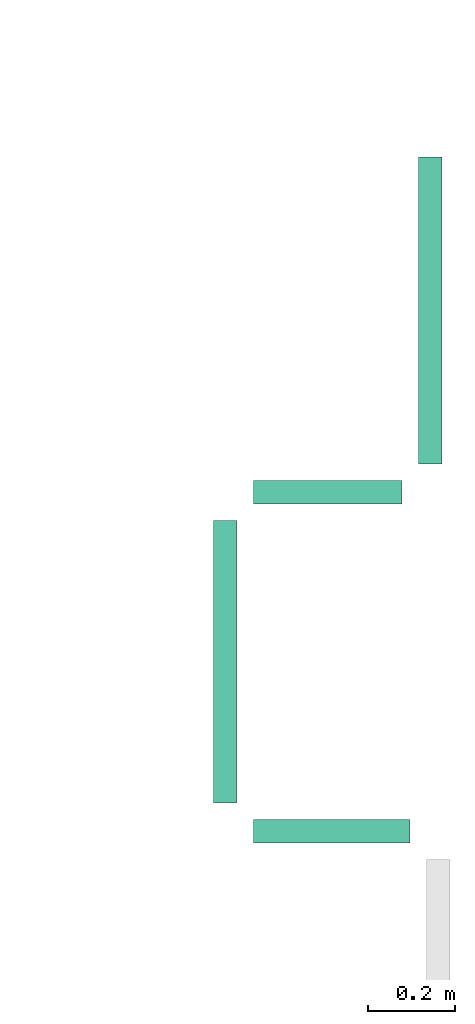
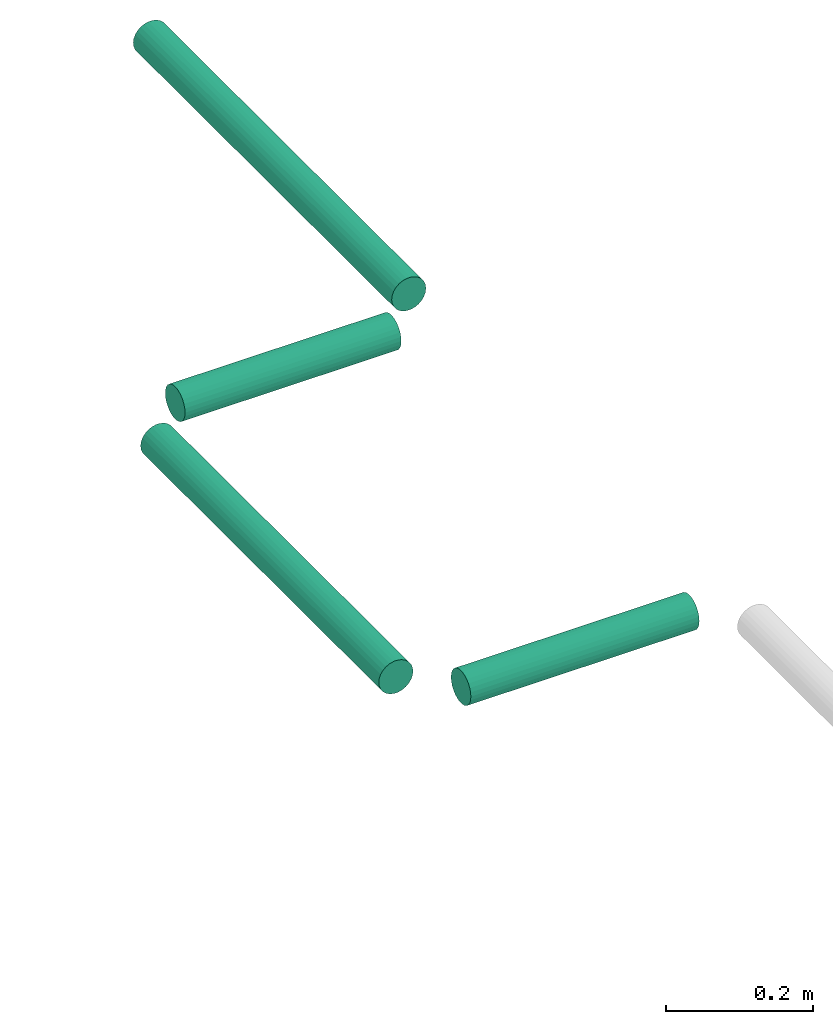
# One storey, part 61 of 89: 4 flow segments.
"""IFC2X3 building model written with IfcOpenShell, lengths in millimetres."""

import ifcopenshell
import ifcopenshell.guid

model = None  # the IFC model being written
_history = None  # IfcOwnerHistory: only IFC2X3 demands one
_inside = {}  # id of a spatial element -> (the spatial element, [elements in it])
_under = {}  # id of a project, library or spatial element -> (it, [spatial elements below it])
_declared = {}  # id of a project -> (the project, [libraries it declares])
_typed = {}  # id of a type object -> (the type object, [elements of that type])
_made_of = {}  # id of a material, layer set ... -> (it, [elements and type objects made of it])


def new_model(schema):
    """Start an empty IFC model of exactly this schema.

    Asked for "IFC4X3", IfcOpenShell would pick the latest addendum, in which some entities
    have other attributes; the version numbers below select the first issue.
    IFC2X3 requires an IfcOwnerHistory on every rooted entity: one is made here for all.
    """
    global model, _history
    if schema == "IFC4X3":
        model = ifcopenshell.file(schema_version=(4, 3, 0, 0))
    else:
        model = ifcopenshell.file(schema=schema)
    _inside.clear()
    _under.clear()
    _declared.clear()
    _typed.clear()
    _made_of.clear()
    _history = None
    if model.schema == "IFC2X3":
        org = make("IfcOrganization", Name="unknown")
        user = make(
            "IfcPersonAndOrganization",
            ThePerson=make("IfcPerson", FamilyName="unknown"),
            TheOrganization=org,
        )
        app = make(
            "IfcApplication",
            ApplicationDeveloper=org,
            Version="unknown",
            ApplicationFullName="unknown",
            ApplicationIdentifier="unknown",
        )
        _history = make(
            "IfcOwnerHistory",
            OwningUser=user,
            OwningApplication=app,
            ChangeAction="ADDED",
            CreationDate=0,
        )
    return model


def make(cls, **values):
    """One entity of the class cls with the attributes given. An attribute that is None is left unset."""
    return model.create_entity(
        cls, **{name: value for name, value in values.items() if value is not None}
    )


def entity(cls, *values):
    """Any entity or typed value of the class cls, its attributes in the order of the schema. None: left unset."""
    e = model.create_entity(cls)
    for i, value in enumerate(values):
        if value is not None:
            e[i] = value
    return e


def rooted(cls, **values):
    """An entity with a GlobalId (a new one), such as an element, a storey or a relation."""
    return make(cls, GlobalId=ifcopenshell.guid.new(), OwnerHistory=_history, **values)


def si_unit(unit_type, name, prefix=None):
    """IfcSIUnit, for example si_unit("LENGTHUNIT", "METRE", prefix="MILLI")."""
    return make("IfcSIUnit", UnitType=unit_type, Prefix=prefix, Name=name)


def converted_unit(unit_type, name, factor, base, dimensions=None, offset=None):
    """IfcConversionBasedUnit, such as the inch: factor (a typed value) times the base unit."""
    return make(
        "IfcConversionBasedUnit"
        if offset is None
        else "IfcConversionBasedUnitWithOffset",
        ConversionOffset=offset,
        Dimensions=None
        if dimensions is None
        else entity("IfcDimensionalExponents", *dimensions),
        UnitType=unit_type,
        Name=name,
        ConversionFactor=make(
            "IfcMeasureWithUnit", ValueComponent=factor, UnitComponent=base
        ),
    )


def derived_unit(unit_type, elements):
    """IfcDerivedUnit: a product of units, each with its exponent."""
    return make(
        "IfcDerivedUnit",
        Elements=[
            make("IfcDerivedUnitElement", Unit=unit, Exponent=power)
            for unit, power in elements
        ],
        UnitType=unit_type,
    )


def assignment(units):
    """IfcUnitAssignment: the units of a project."""
    return None if units is None else make("IfcUnitAssignment", Units=units)


def point(xyz):
    """IfcCartesianPoint."""
    return None if xyz is None else make("IfcCartesianPoint", Coordinates=xyz)


def direction(xyz):
    """IfcDirection."""
    return None if xyz is None else make("IfcDirection", DirectionRatios=xyz)


def frame(location, z_axis=None, x_axis=None):
    """IfcAxis2Placement3D, a coordinate frame: its origin and axes. An axis left out is left unset."""
    return make(
        "IfcAxis2Placement3D",
        Location=point(location),
        Axis=direction(z_axis),
        RefDirection=direction(x_axis),
    )


def frame_2d(location, x_axis=None):
    """IfcAxis2Placement2D, a coordinate frame in the plane: its origin and x axis."""
    return make(
        "IfcAxis2Placement2D", Location=point(location), RefDirection=direction(x_axis)
    )


def origin():
    """The frame at (0, 0, 0) with its axes left unset."""
    return frame((0.0, 0.0, 0.0))


def origin_2d_with_axis():
    """The frame at (0, 0) in the plane with the x axis (1, 0) written out."""
    return frame_2d((0.0, 0.0), x_axis=(1.0, 0.0))


def place(relative_to, where):
    """IfcLocalPlacement: puts the frame where relative to a parent placement (None: the world)."""
    return make(
        "IfcLocalPlacement", PlacementRelTo=relative_to, RelativePlacement=where
    )


def context(
    kind, dimensions, precision=None, world=None, true_north=None, identifier=None
):
    """IfcGeometricRepresentationContext, for example the 3D "Model" context."""
    return make(
        "IfcGeometricRepresentationContext",
        ContextIdentifier=identifier,
        ContextType=kind,
        CoordinateSpaceDimension=dimensions,
        Precision=precision,
        WorldCoordinateSystem=world,
        TrueNorth=true_north,
    )


def subcontext(parent, identifier, kind, view, scale=None):
    """IfcGeometricRepresentationSubContext, for example "Body" below "Model"."""
    return make(
        "IfcGeometricRepresentationSubContext",
        ContextIdentifier=identifier,
        ContextType=kind,
        ParentContext=parent,
        TargetScale=scale,
        TargetView=view,
    )


def project(units=None, contexts=None):
    """IfcProject with its units and contexts."""
    return rooted(
        "IfcProject",
        Name="project",
        RepresentationContexts=contexts,
        UnitsInContext=assignment(units),
    )


def spatial(cls, under=None, at=None, **own):
    """A site, building, storey or space (cls), placed at a placement, below another one or the project."""
    s = rooted(cls, ObjectPlacement=at, **own)
    if under is not None:
        _under.setdefault(under.id(), (under, []))[1].append(s)
    return s


def profile(cls, at=None, kind="AREA", **sizes):
    """A parametric profile (cls). Its sizes go by their IFC names, for example OverallWidth=200.0."""
    return make(cls, ProfileType=kind, Position=at, **sizes)


def circle(**sizes):
    """IfcCircleProfileDef."""
    return profile("IfcCircleProfileDef", **sizes)


def extrude(swept, where, along, depth):
    """IfcExtrudedAreaSolid: the profile swept, set in the frame where, extruded along a direction by depth."""
    return make(
        "IfcExtrudedAreaSolid",
        SweptArea=swept,
        Position=where,
        ExtrudedDirection=direction(along),
        Depth=depth,
    )


def shape(context_of_items, identifier, shape_type, items):
    """IfcShapeRepresentation: the items that make up one representation, for example the "Body"."""
    return make(
        "IfcShapeRepresentation",
        ContextOfItems=context_of_items,
        RepresentationIdentifier=identifier,
        RepresentationType=shape_type,
        Items=items,
    )


def made_of(thing, what):
    """Note that an element or type object is made of a material, layer set ...; save() writes the relation."""
    if what is not None:
        _made_of.setdefault(what.id(), (what, []))[1].append(thing)
    return thing


def type_object(cls, material=None, **own):
    """A type object (cls), such as IfcWallType, which elements share."""
    return made_of(rooted(cls, **own), material)


def element(
    cls,
    number,
    at=None,
    inside=None,
    cuts=None,
    type_object=None,
    material=None,
    context=None,
    identifier="Body",
    shape_type=None,
    held_by="IfcProductDefinitionShape",
    body=None,
    shapes=None,
    **own,
):
    """One element of the class cls, such as IfcWall. Its Tag is "e" and its number.

    at: its placement. inside: the storey or other place that contains it. cuts: it is an
    opening in that element (IfcRelVoidsElement). A single representation is given by context,
    identifier, shape_type and body (its items); several are given by shapes. held_by: the class
    of the entity that holds the representations. save() writes the other relations.
    """
    e = rooted(cls, Tag="e%d" % number, ObjectPlacement=at, **own)
    if body is not None:
        shapes = [shape(context, identifier, shape_type, body)]
    if shapes is not None:
        e.Representation = make(held_by, Representations=shapes)
    if inside is not None:
        _inside.setdefault(inside.id(), (inside, []))[1].append(e)
    if cuts is not None:
        rooted(
            "IfcRelVoidsElement", RelatingBuildingElement=cuts, RelatedOpeningElement=e
        )
    if type_object is not None:
        _typed.setdefault(type_object.id(), (type_object, []))[1].append(e)
    return made_of(e, material)


def aggregate(whole, parts):
    """IfcRelAggregates: a whole, such as a stair, and the parts it consists of."""
    return rooted("IfcRelAggregates", RelatingObject=whole, RelatedObjects=parts)


def save(model, path):
    """Write the relations noted so far, then the file.

    IfcRelAggregates (storeys below a building ...), IfcRelContainedInSpatialStructure (elements
    in a storey), IfcRelDefinesByType, IfcRelAssociatesMaterial and IfcRelDeclares: one each for
    every whole, place, type object, material and project.
    """
    for whole, parts in _under.values():
        aggregate(whole, parts)
    for where, things in _inside.values():
        rooted(
            "IfcRelContainedInSpatialStructure",
            RelatedElements=things,
            RelatingStructure=where,
        )
    for kind, things in _typed.values():
        rooted("IfcRelDefinesByType", RelatedObjects=things, RelatingType=kind)
    for what, things in _made_of.values():
        rooted("IfcRelAssociatesMaterial", RelatedObjects=things, RelatingMaterial=what)
    for by, libraries in _declared.values():
        rooted("IfcRelDeclares", RelatingContext=by, RelatedDefinitions=libraries)
    model.write(path)


model = new_model("IFC2X3")

# Units and contexts
model_context = context("Model", 3, precision=0.01, world=origin(), true_north=direction((6.12303176911189e-17, 1.0)))
body_context = subcontext(model_context, "Body", "Model", "MODEL_VIEW")
ifc_project = project(units=[si_unit("LENGTHUNIT", "METRE", prefix="MILLI"), si_unit("AREAUNIT", "SQUARE_METRE"), si_unit("VOLUMEUNIT", "CUBIC_METRE"), converted_unit("PLANEANGLEUNIT", "DEGREE", entity("IfcRatioMeasure", 0.0174532925199433), si_unit("PLANEANGLEUNIT", "RADIAN"), dimensions=[0, 0, 0, 0, 0, 0, 0]), si_unit("MASSUNIT", "GRAM", prefix="KILO"), derived_unit("MASSDENSITYUNIT", [(si_unit("MASSUNIT", "GRAM", prefix="KILO"), 1), (si_unit("LENGTHUNIT", "METRE"), -3)]), derived_unit("MOMENTOFINERTIAUNIT", [(si_unit("LENGTHUNIT", "METRE"), 4)]), si_unit("TIMEUNIT", "SECOND"), si_unit("FREQUENCYUNIT", "HERTZ"), si_unit("THERMODYNAMICTEMPERATUREUNIT", "DEGREE_CELSIUS"), derived_unit("THERMALTRANSMITTANCEUNIT", [(si_unit("MASSUNIT", "GRAM", prefix="KILO"), 1), (si_unit("THERMODYNAMICTEMPERATUREUNIT", "KELVIN"), -1), (si_unit("TIMEUNIT", "SECOND"), -3)]), derived_unit("VOLUMETRICFLOWRATEUNIT", [(si_unit("LENGTHUNIT", "METRE"), 3), (si_unit("TIMEUNIT", "SECOND"), -1)]), derived_unit("MASSFLOWRATEUNIT", [(si_unit("MASSUNIT", "GRAM", prefix="KILO"), 1), (si_unit("TIMEUNIT", "SECOND"), -1)]), derived_unit("ROTATIONALFREQUENCYUNIT", [(si_unit("TIMEUNIT", "SECOND"), -1)]), si_unit("ELECTRICCURRENTUNIT", "AMPERE"), si_unit("ELECTRICVOLTAGEUNIT", "VOLT"), si_unit("POWERUNIT", "WATT"), si_unit("FORCEUNIT", "NEWTON", prefix="KILO"), si_unit("ILLUMINANCEUNIT", "LUX"), si_unit("LUMINOUSFLUXUNIT", "LUMEN"), si_unit("LUMINOUSINTENSITYUNIT", "CANDELA"), derived_unit("USERDEFINED", [(si_unit("MASSUNIT", "GRAM", prefix="KILO"), -1), (si_unit("LENGTHUNIT", "METRE"), -2), (si_unit("TIMEUNIT", "SECOND"), 3), (si_unit("LUMINOUSFLUXUNIT", "LUMEN"), 1)]), derived_unit("LINEARVELOCITYUNIT", [(si_unit("LENGTHUNIT", "METRE"), 1), (si_unit("TIMEUNIT", "SECOND"), -1)]), si_unit("PRESSUREUNIT", "PASCAL"), derived_unit("USERDEFINED", [(si_unit("LENGTHUNIT", "METRE"), -2), (si_unit("MASSUNIT", "GRAM", prefix="KILO"), 1), (si_unit("TIMEUNIT", "SECOND"), -2)]), derived_unit("LINEARFORCEUNIT", [(si_unit("MASSUNIT", "GRAM", prefix="KILO"), 1), (si_unit("LENGTHUNIT", "METRE"), 1), (si_unit("TIMEUNIT", "SECOND"), -2), (si_unit("LENGTHUNIT", "METRE"), -1)]), derived_unit("PLANARFORCEUNIT", [(si_unit("MASSUNIT", "GRAM", prefix="KILO"), 1), (si_unit("LENGTHUNIT", "METRE"), 1), (si_unit("TIMEUNIT", "SECOND"), -2), (si_unit("LENGTHUNIT", "METRE"), -2)])], contexts=[model_context])

# Site, building, storey
site_placement = place(None, frame((0.0, -0.00077364408347762, 0.0)))
site = spatial("IfcSite", under=ifc_project, at=site_placement, CompositionType="ELEMENT")
building_placement = place(site_placement, origin())
building = spatial("IfcBuilding", under=site, at=building_placement, CompositionType="ELEMENT")
storey_placement = place(building_placement, frame((0.0, 0.0, 24000.0)))
storey = spatial("IfcBuildingStorey", under=building, at=storey_placement, CompositionType="ELEMENT", Elevation=24000.0)

# Flow segments
pipe_segment_type = type_object("IfcPipeSegmentType", PredefinedType="NOTDEFINED")
flow_segment_1_placement = place(storey_placement, frame((72871.1895827871, 15296.6520722135, 2421.40472776407)))
element("IfcFlowSegment", 1, at=flow_segment_1_placement, inside=storey, type_object=pipe_segment_type, context=body_context, shape_type="SweptSolid", body=[
    extrude(circle(Radius=27.0, at=origin_2d_with_axis()), frame((0.0, 28.5952722359163, 28.5952722359141), z_axis=(1.0, 0.0, 0.0), x_axis=(0.0, -1.0, 0.0)), (0.0, 0.0, 1.0), 340.657209361523),
])
flow_segment_2_placement = place(storey_placement, frame((73248.2515199127, 15390.2473444494, 2421.40472776407)))
element("IfcFlowSegment", 2, at=flow_segment_2_placement, inside=storey, type_object=pipe_segment_type, context=body_context, shape_type="SweptSolid", body=[
    extrude(circle(Radius=27.0, at=origin_2d_with_axis()), frame((28.5952722359271, 0.0, 28.5952722359141), z_axis=(0.0, 1.0, 0.0), x_axis=(1.0, 0.0, 0.0)), (0.0, 0.0, 1.0), 705.315926750812),
])
flow_segment_3_placement = place(storey_placement, frame((72777.5943105512, 14610.2473444494, 2421.40472776407)))
element("IfcFlowSegment", 3, at=flow_segment_3_placement, inside=storey, type_object=pipe_segment_type, context=body_context, shape_type="SweptSolid", body=[
    extrude(circle(Radius=27.0, at=origin_2d_with_axis()), frame((28.5952722359271, 0.0, 28.5952722359141), z_axis=(0.0, 1.0, 0.0), x_axis=(1.0, 0.0, 0.0)), (0.0, 0.0, 1.0), 650.000000000013),
])
flow_segment_4_placement = place(storey_placement, frame((72871.1895827871, 14516.6520722135, 2421.40472776407)))
element("IfcFlowSegment", 4, at=flow_segment_4_placement, inside=storey, type_object=pipe_segment_type, context=body_context, shape_type="SweptSolid", body=[
    extrude(circle(Radius=27.0, at=frame_2d((0.0, -4.33146851719357e-12), x_axis=(1.0, 0.0))), frame((0.0, 28.5952722359141, 28.5952722359098), z_axis=(1.0, 0.0, 0.0), x_axis=(0.0, -1.0, 0.0)), (0.0, 0.0, 1.0), 359.892567795953),
])

save(model, "model.ifc")
